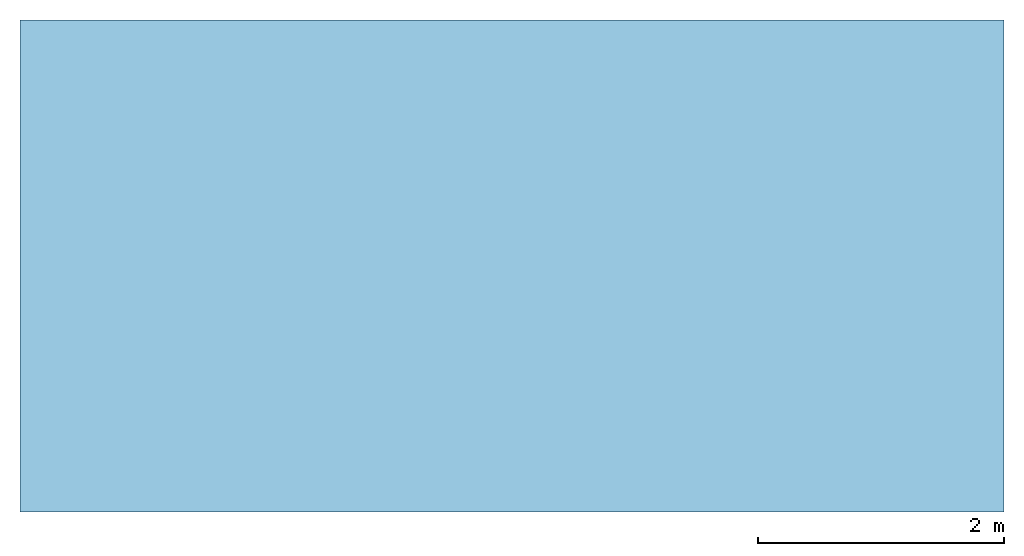
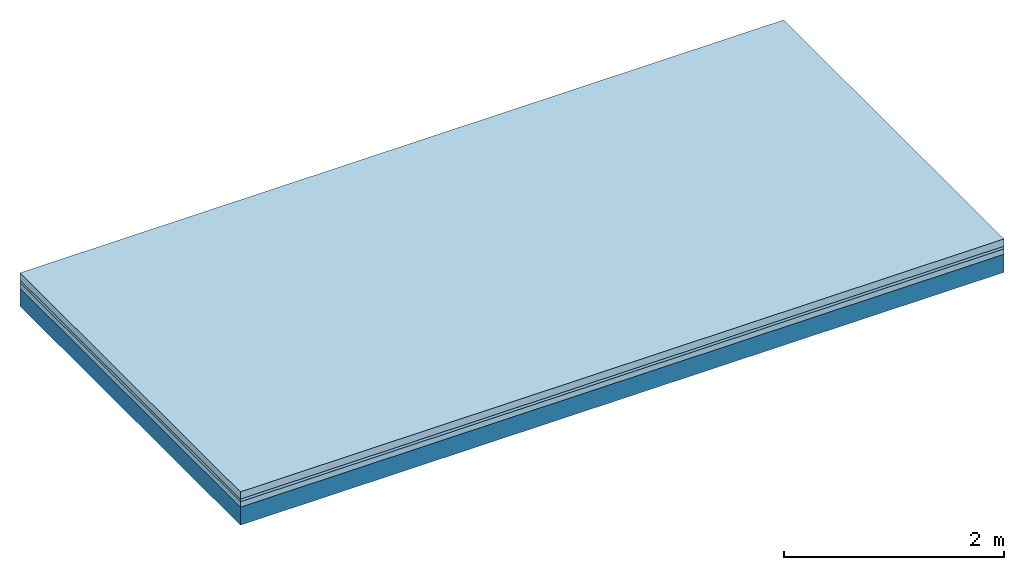
# One storey: 3 plates, 1 member, 1 element without a shape of its own.
"""IFC4 building model written with IfcOpenShell, lengths in metres."""

from ifc_helpers import new_model, si_unit, derived_unit, direction, frame, frame_2d, origin, origin_with_axes, place, context, project, spatial, rectangle, extrude, material, layer, layer_set, type_object, element, aggregate, save


model = new_model("IFC4")

# Units and contexts
plan_context = context("Plan", 3, precision=1e-05, world=origin(), true_north=direction((0.0, 1.0)))
model_context = context("Model", 3, precision=1e-05, world=origin(), true_north=direction((0.0, 1.0)))
ifc_project = project(units=[si_unit("LENGTHUNIT", "METRE"), derived_unit("SOUNDPRESSUREUNIT", [(si_unit("PRESSUREUNIT", "PASCAL", prefix="MICRO"), 0)]), si_unit("ENERGYUNIT", "JOULE", prefix="MEGA"), si_unit("MASSUNIT", "GRAM", prefix="KILO"), derived_unit("THERMALTRANSMITTANCEUNIT", [(si_unit("POWERUNIT", "WATT"), 1), (si_unit("AREAUNIT", "SQUARE_METRE"), -1), (si_unit("THERMODYNAMICTEMPERATUREUNIT", "KELVIN"), -1)]), derived_unit("AREADENSITYUNIT", [(si_unit("MASSUNIT", "GRAM", prefix="KILO"), 1), (si_unit("AREAUNIT", "SQUARE_METRE"), -1)]), derived_unit("USERDEFINED", [(si_unit("ENERGYUNIT", "JOULE", prefix="MEGA"), 1), (si_unit("AREAUNIT", "SQUARE_METRE"), -1)])], contexts=[plan_context, model_context])

# Site, building, storey
site = spatial("IfcSite", under=ifc_project)
building_placement = place(None, origin())
building = spatial("IfcBuilding", under=site, at=building_placement)
storey_placement = place(building_placement, origin())
storey = spatial("IfcBuildingStorey", under=building, at=storey_placement)

# Slab, member, plates
ifc_material_1 = material(Name="Cement screed", Category="04.006")
ifc_layer_1 = layer(ifc_material_1, 0.08, Name="On-material")
ifc_material_2 = material()
ifc_layer_2 = layer(ifc_material_2, 0.03, Name="Impact sound insulation")
ifc_material_3 = material(Category="03.011")
ifc_layer_3 = layer(ifc_material_3, 0.06, Name="on Supporting structure")
ifc_layer_4 = layer(None, 0.2, Name="Supporting structure")
ifc_layer_set = layer_set([ifc_layer_1, ifc_layer_2, ifc_layer_3, ifc_layer_4])
slab_type = type_object("IfcSlabType", Name="A1088", PredefinedType="NOTDEFINED", material=ifc_layer_set)
slab_placement = place(None, frame((0.0, 0.0, 0.0), z_axis=(0.0, 0.0, -1.0), x_axis=(1.0, 0.0, 0.0)))
slab = element("IfcSlab", 1, at=slab_placement, inside=storey, type_object=slab_type, material=ifc_layer_set, Name="Slab #1")
ifc_material_4 = material()
member_placement = place(slab_placement, origin())
member = element("IfcMember", 2, at=member_placement, material=ifc_material_4, Name="Supporting structure", context=plan_context, shape_type="SweptSolid", body=[
    extrude(rectangle(XDim=1.0, YDim=0.2, at=frame_2d((0.5, 0.1), x_axis=(1.0, 0.0))), frame((0.0, 4.0, 0.17), z_axis=(0.0, -1.0, 0.0), x_axis=(1.0, 0.0, 0.0)), (0.0, 0.0, 1.0), 4.0),
    extrude(rectangle(XDim=1.0, YDim=0.2, at=frame_2d((0.5, 0.1), x_axis=(1.0, 0.0))), frame((1.0, 4.0, 0.17), z_axis=(0.0, -1.0, 0.0), x_axis=(1.0, 0.0, 0.0)), (0.0, 0.0, 1.0), 4.0),
    extrude(rectangle(XDim=1.0, YDim=0.2, at=frame_2d((0.5, 0.1), x_axis=(1.0, 0.0))), frame((2.0, 4.0, 0.17), z_axis=(0.0, -1.0, 0.0), x_axis=(1.0, 0.0, 0.0)), (0.0, 0.0, 1.0), 4.0),
    extrude(rectangle(XDim=1.0, YDim=0.2, at=frame_2d((0.5, 0.1), x_axis=(1.0, 0.0))), frame((3.0, 4.0, 0.17), z_axis=(0.0, -1.0, 0.0), x_axis=(1.0, 0.0, 0.0)), (0.0, 0.0, 1.0), 4.0),
    extrude(rectangle(XDim=1.0, YDim=0.2, at=frame_2d((0.5, 0.1), x_axis=(1.0, 0.0))), frame((4.0, 4.0, 0.17), z_axis=(0.0, -1.0, 0.0), x_axis=(1.0, 0.0, 0.0)), (0.0, 0.0, 1.0), 4.0),
    extrude(rectangle(XDim=1.0, YDim=0.2, at=frame_2d((0.5, 0.1), x_axis=(1.0, 0.0))), frame((5.0, 4.0, 0.17), z_axis=(0.0, -1.0, 0.0), x_axis=(1.0, 0.0, 0.0)), (0.0, 0.0, 1.0), 4.0),
    extrude(rectangle(XDim=1.0, YDim=0.2, at=frame_2d((0.5, 0.1), x_axis=(1.0, 0.0))), frame((6.0, 4.0, 0.17), z_axis=(0.0, -1.0, 0.0), x_axis=(1.0, 0.0, 0.0)), (0.0, 0.0, 1.0), 4.0),
    extrude(rectangle(XDim=1.0, YDim=0.2, at=frame_2d((0.5, 0.1), x_axis=(1.0, 0.0))), frame((7.0, 4.0, 0.17), z_axis=(0.0, -1.0, 0.0), x_axis=(1.0, 0.0, 0.0)), (0.0, 0.0, 1.0), 4.0),
])
plate_1_placement = place(slab_placement, origin())
plate_1 = element("IfcPlate", 3, at=plate_1_placement, material=ifc_material_1, Name="On-material", context=plan_context, shape_type="SweptSolid", body=[
    extrude(rectangle(XDim=8.0, YDim=4.0, at=frame_2d((4.0, 2.0), x_axis=(1.0, 0.0))), origin_with_axes(), (0.0, 0.0, 1.0), 0.08),
])
plate_2_placement = place(slab_placement, origin())
plate_2 = element("IfcPlate", 4, at=plate_2_placement, material=ifc_material_2, Name="Impact sound insulation", context=plan_context, shape_type="SweptSolid", body=[
    extrude(rectangle(XDim=8.0, YDim=4.0, at=frame_2d((4.0, 2.0), x_axis=(1.0, 0.0))), frame((0.0, 0.0, 0.08), z_axis=(0.0, 0.0, 1.0), x_axis=(1.0, 0.0, 0.0)), (0.0, 0.0, 1.0), 0.03),
])
plate_3_placement = place(slab_placement, origin())
plate_3 = element("IfcPlate", 5, at=plate_3_placement, material=ifc_material_3, Name="on Supporting structure", context=plan_context, shape_type="SweptSolid", body=[
    extrude(rectangle(XDim=8.0, YDim=4.0, at=frame_2d((4.0, 2.0), x_axis=(1.0, 0.0))), frame((0.0, 0.0, 0.11), z_axis=(0.0, 0.0, 1.0), x_axis=(1.0, 0.0, 0.0)), (0.0, 0.0, 1.0), 0.06),
])
aggregate(slab, [plate_1, plate_2, plate_3, member])

save(model, "model.ifc")
